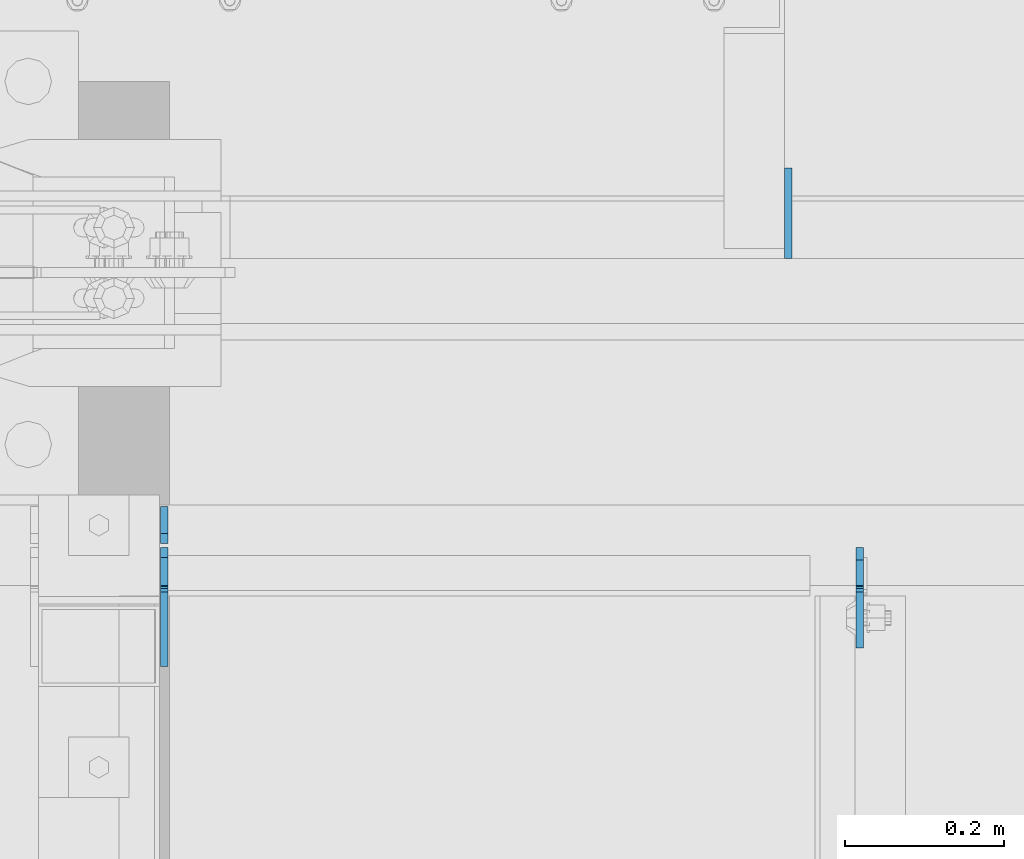
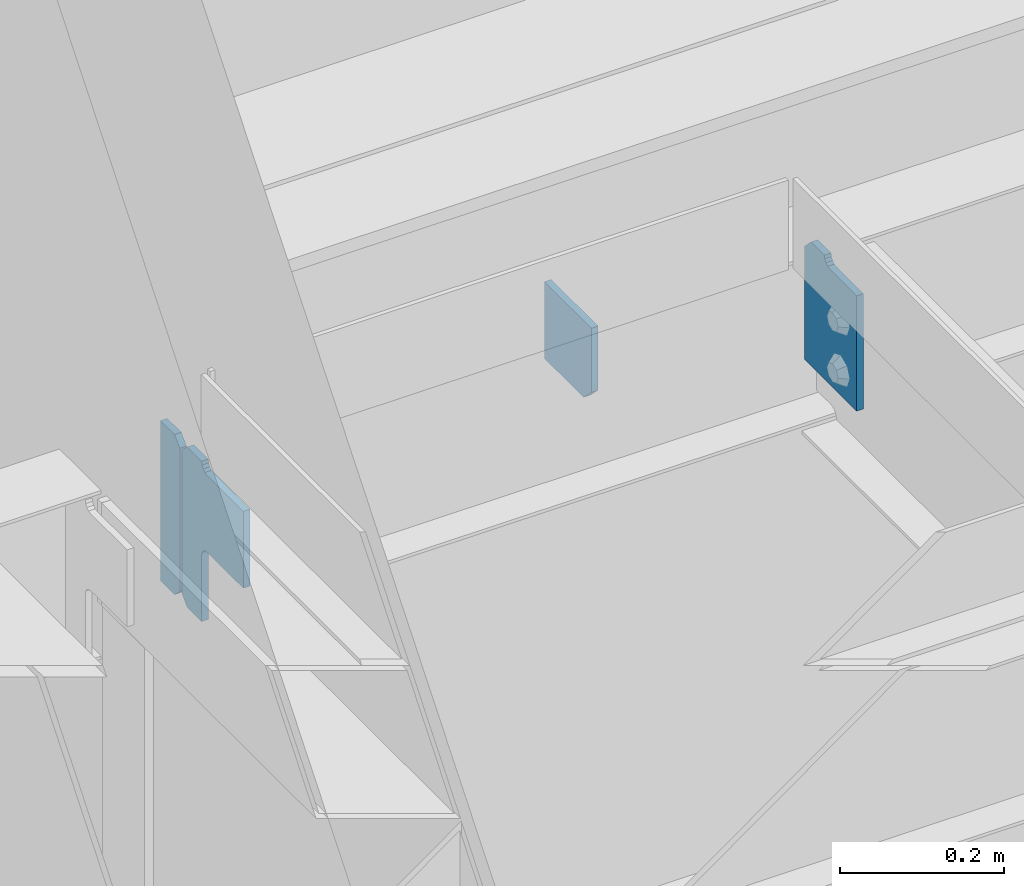
# One storey, part 1110 of 1179: 4 plates, 3 elements without a shape of their own.
"""IFC2X3 building model written with IfcOpenShell, lengths in millimetres."""

from ifc_helpers import new_model, si_unit, frame, origin_with_axes, place, context, subcontext, project, spatial, faceted_brep, material, type_object, element, aggregate, save


model = new_model("IFC2X3")

# Units and contexts
model_context = context("Model", 3, precision=1e-05, world=origin_with_axes())
body_context = subcontext(model_context, "Body", "Model", "MODEL_VIEW")
ifc_project = project(units=[si_unit("LENGTHUNIT", "METRE", prefix="MILLI"), si_unit("AREAUNIT", "SQUARE_METRE"), si_unit("VOLUMEUNIT", "CUBIC_METRE"), si_unit("MASSUNIT", "GRAM", prefix="KILO"), si_unit("TIMEUNIT", "SECOND"), si_unit("PLANEANGLEUNIT", "RADIAN"), si_unit("SOLIDANGLEUNIT", "STERADIAN"), si_unit("THERMODYNAMICTEMPERATUREUNIT", "DEGREE_CELSIUS"), si_unit("LUMINOUSINTENSITYUNIT", "LUMEN")], contexts=[model_context])

# Site, building, storey
site_placement = place(None, origin_with_axes())
site = spatial("IfcSite", under=ifc_project, at=site_placement, CompositionType="ELEMENT")
building_placement = place(site_placement, origin_with_axes())
building = spatial("IfcBuilding", under=site, at=building_placement, Name="Undefined", CompositionType="ELEMENT")
storey_placement = place(building_placement, origin_with_axes())
storey = spatial("IfcBuildingStorey", under=building, at=storey_placement, Name="Undefined", CompositionType="ELEMENT", Elevation=0.0)

# Assembly, plates
assembly_1_placement = place(storey_placement, origin_with_axes())
assembly_1 = element("IfcElementAssembly", 1, at=assembly_1_placement, inside=storey, Name="BEAM", AssemblyPlace="NOTDEFINED", PredefinedType="RIGID_FRAME")
ifc_material = material(Name="STEEL/A36")
plate_type_1 = type_object("IfcPlateType", PredefinedType="NOTDEFINED")
plate_1_placement = place(assembly_1_placement, frame((17734.7557500839, 40840.81875, 12928.6), z_axis=(0.0, 0.0, 1.0), x_axis=(0.0, -1.0, 0.0)))
plate_1 = element("IfcPlate", 2, at=plate_1_placement, type_object=plate_type_1, material=ifc_material, Name="PLATE", context=body_context, shape_type="Brep", body=[
    faceted_brep([(15.875, -4.76250000000073, 184.15), (15.875, 4.76250000000073, 184.15), (0.0, 4.76250000000073, 168.275), (0.0, -4.76250000000073, 168.275), (127.0, -4.76250000000073, 0.0), (0.0, -4.76249999999709, 0.0), (0.0, 4.76249999999709, 0.0), (127.0, 4.76250000000073, 0.0), (127.0, 4.76250000000073, 171.449999999999), (127.0, -4.76250000000073, 171.449999999999), (61.1187498092695, 4.76250000000073, 171.449999999999), (61.1187498092695, -4.76250000000073, 171.449999999999), (56.2586702912231, 4.76250000000073, 172.416729922586), (56.2586702912231, -4.76250000000073, 172.416729922586), (52.1384938230694, 4.76250000000073, 175.169743823064), (52.1384938230694, -4.76250000000073, 175.169743823064), (49.3854799225956, 4.76250000000073, 179.289920291218), (49.3854799225956, -4.76250000000073, 179.289920291218), (48.4187500000044, 4.76250000000073, 184.15), (48.4187500000044, -4.76250000000073, 184.15)], [[[0, 1, 2, 3]], [[4, 5, 6, 7]], [[4, 7, 8, 9]], [[9, 8, 10, 11]], [[11, 10, 12, 13]], [[13, 12, 14, 15]], [[15, 14, 16, 17]], [[17, 16, 18, 19]], [[5, 4, 9, 11, 13, 15, 17, 19, 0, 3]], [[6, 5, 3, 2]], [[18, 16, 14, 12, 10, 8, 7, 6, 2, 1]], [[19, 18, 1, 0]]]),
])
plate_type_2 = type_object("IfcPlateType", PredefinedType="NOTDEFINED")
plate_2_placement = place(assembly_1_placement, frame((16859.2499982185, 40845.58125, 12874.625), z_axis=(0.0, 0.0, 1.0), x_axis=(0.0, 1.0, 0.0)))
plate_2 = element("IfcPlate", 3, at=plate_2_placement, type_object=plate_type_2, material=ifc_material, Name="PLATE", context=body_context, shape_type="Brep", body=[
    faceted_brep([(-2.72848410531878e-12, -4.76249999998981, 12.6999998092615), (0.0, -4.76250000000073, 225.425000190735), (0.0, 4.76250000000073, 225.425000190735), (-2.72848410531878e-12, 4.76250000000437, 12.699999809256), (12.6999998092651, -4.76250000000073, 238.125), (12.6999998092651, 4.76250000000073, 238.125), (46.8312500000029, -4.76250000000073, 238.125), (46.8312500000029, 4.76250000000073, 238.125), (46.8312500000029, -4.76249999999982, 0.0), (46.8312500000029, 4.76249999999982, 0.0), (12.6999998092651, -4.76249999999527, 1.81898940354586e-12), (12.6999998092651, 4.76250000000073, 0.0)], [[[0, 1, 2, 3]], [[1, 4, 5, 2]], [[4, 6, 7, 5]], [[6, 8, 9, 7]], [[8, 10, 11, 9]], [[10, 0, 3, 11]], [[5, 7, 9, 11, 3, 2]], [[10, 8, 6, 4, 1, 0]]]),
])
aggregate(assembly_1, [plate_1, plate_2])

# Assembly, plate
assembly_2_placement = place(storey_placement, origin_with_axes())
assembly_2 = element("IfcElementAssembly", 4, at=assembly_2_placement, inside=storey, Name="BEAM", AssemblyPlace="NOTDEFINED", PredefinedType="RIGID_FRAME")
plate_type_3 = type_object("IfcPlateType", PredefinedType="NOTDEFINED")
plate_3_placement = place(assembly_2_placement, frame((17645.0625, 41204.35625, 12690.4749987075), z_axis=(0.0, 0.707106781186542, 0.707106781186553), x_axis=(0.0, 0.707106781186553, -0.707106781186542)))
plate_3 = element("IfcPlate", 5, at=plate_3_placement, type_object=plate_type_3, material=ifc_material, Name="PLATE", context=body_context, shape_type="Brep", body=[
    faceted_brep([(0.0, -4.76249999999709, 0.0), (-67.3519210815575, -4.76250000000073, 67.3519210815502), (-67.3519210815575, 4.76250000000073, 67.3519210815502), (0.0, 4.76249999999709, 0.0), (13.4703845975746, -4.76250000000073, 148.174224853334), (13.4703845975746, 4.76250000000073, 148.174224853334), (94.2926864622132, -4.76250000000073, 67.3519210813465), (94.2926864622132, 4.76250000000073, 67.3519210813465), (26.9407683631525, -4.76249999999709, -6.18456397205591e-11), (26.9407683631525, 4.76249999999709, -6.18456397205591e-11)], [[[0, 1, 2, 3]], [[1, 4, 5, 2]], [[4, 6, 7, 5]], [[6, 8, 9, 7]], [[8, 0, 3, 9]], [[5, 7, 9, 3, 2]], [[8, 6, 4, 1, 0]]]),
])
aggregate(assembly_2, [plate_3])

assembly_3_placement = place(storey_placement, origin_with_axes())
assembly_3 = element("IfcElementAssembly", 6, at=assembly_3_placement, inside=storey, Name="PLATE", AssemblyPlace="NOTDEFINED", PredefinedType="RIGID_FRAME")
plate_type_4 = type_object("IfcPlateType", PredefinedType="NOTDEFINED")
plate_4_placement = place(assembly_3_placement, frame((16859.2499982185, 40840.818750027, 13112.75), z_axis=(0.0, -1.0, 0.0), x_axis=(0.0, 0.0, -1.0)))
plate_4 = element("IfcPlate", 7, at=plate_4_placement, type_object=plate_type_4, material=ifc_material, Name="PLATE", context=body_context, shape_type="Brep", body=[
    faceted_brep([(4.8600797445506, -4.76249999992433, 49.3854800566332), (4.8600797445506, 4.76250000007713, 49.3854798566099), (-1.45519152283669e-11, 4.76249999999345, 48.4187388288169), (-9.09494701772928e-12, -4.76249999999891, 48.4187388288169), (8.98025619343389, -4.76249999991705, 52.138493985949), (8.98025619343389, 4.76250000008076, 52.1384937859257), (11.7332700650695, -4.76249999990978, 56.2586704733694), (11.7332700650695, 4.76250000009168, 56.2586702733461), (12.6999999536365, -4.7624999999025, 61.1187499981825), (12.6999999536365, 4.76250000009532, 61.1187497981591), (12.6999993313366, -4.76249999976426, 150.018738193074), (12.6999993313366, 4.7625000002372, 150.018738193059), (12.6999998092651, -4.76249999999527, 1.81898940354586e-12), (-2.72848410531878e-12, -4.76249999998981, 12.6999998092615), (-2.72848410531878e-12, 4.76250000000437, 12.699999809256), (12.6999998092651, 4.76250000000073, 0.0), (225.425000190735, -4.76250000000073, -6.54836185276508e-11), (225.425000190735, 4.76250000000073, -8.00355337560177e-11), (238.124999073794, -4.7624999999789, 12.6999998091924), (238.124999073794, 4.76250000001892, 12.6999998091778), (238.124996468841, -4.76249999992433, 48.418751110039), (238.124996468841, 4.76250000007713, 48.4187511100245), (139.700008964539, -4.76250000007713, 48.4187507629322), (139.700008964539, 4.76249999992433, 48.4187507629395), (134.839929446493, -4.76250000007713, 49.3854806855161), (134.839929446493, 4.76249999992433, 49.3854806855306), (130.719752978339, -4.76250000008076, 52.1384945859973), (130.719752978339, 4.76249999991705, 52.1384945860118), (127.966739077861, -4.76250000008804, 56.2586710541509), (127.966739077861, 4.76249999991342, 56.2586710541655), (127.000009155274, -4.76250000009532, 61.1187505721973), (127.000009155274, 4.7624999999025, 61.1187505722046), (127.000009155274, -4.7625000002372, 150.018753051751), (127.000009155274, 4.76249999976426, 150.018753051758)], [[[0, 1, 2, 3]], [[4, 5, 1, 0]], [[6, 7, 5, 4]], [[8, 9, 7, 6]], [[10, 11, 9, 8]], [[12, 13, 14, 15]], [[16, 12, 15, 17]], [[18, 16, 17, 19]], [[20, 18, 19, 21]], [[22, 20, 21, 23]], [[24, 22, 23, 25]], [[26, 24, 25, 27]], [[28, 26, 27, 29]], [[30, 28, 29, 31]], [[32, 30, 31, 33]], [[6, 4, 0, 3, 13, 12, 16, 18, 20, 22, 24, 26, 28, 30, 32, 10, 8]], [[14, 13, 3, 2]], [[33, 31, 29, 27, 25, 23, 21, 19, 17, 15, 14, 2, 1, 5, 7, 9, 11]], [[32, 33, 11, 10]]]),
])
aggregate(assembly_3, [plate_4])

save(model, "model.ifc")
